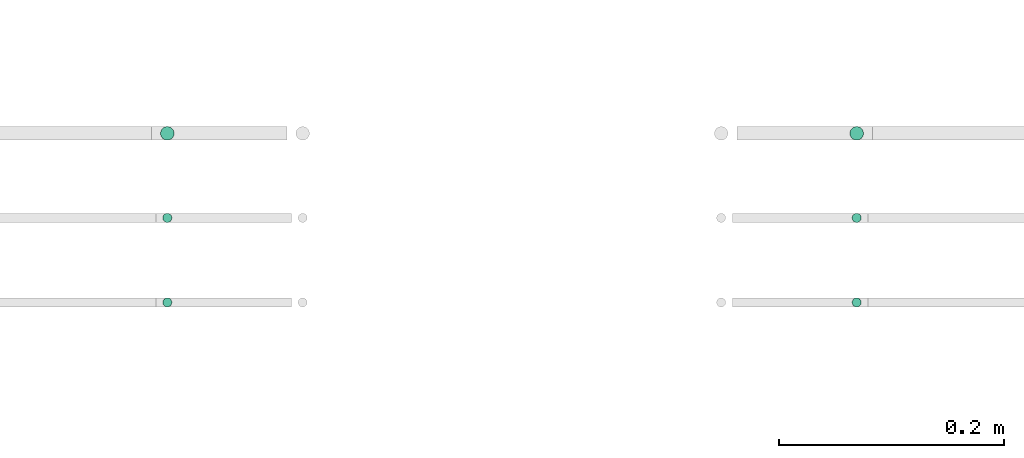
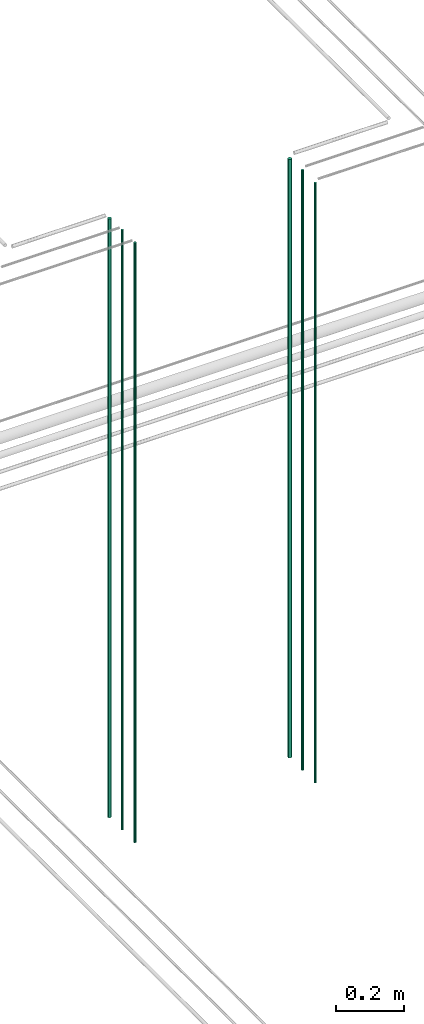
# One storey, part 8 of 331: 6 flow segments.
"""IFC2X3 building model written with IfcOpenShell, lengths in millimetres."""

from ifc_helpers import new_model, entity, si_unit, converted_unit, derived_unit, direction, frame, origin, origin_2d_with_axis, place, context, subcontext, project, spatial, circle, extrude, type_object, element, save


model = new_model("IFC2X3")

# Units and contexts
model_context = context("Model", 3, precision=0.01, world=origin(), true_north=direction((6.12303176911189e-17, 1.0)))
body_context = subcontext(model_context, "Body", "Model", "MODEL_VIEW")
ifc_project = project(units=[si_unit("LENGTHUNIT", "METRE", prefix="MILLI"), si_unit("AREAUNIT", "SQUARE_METRE"), si_unit("VOLUMEUNIT", "CUBIC_METRE"), converted_unit("PLANEANGLEUNIT", "DEGREE", entity("IfcRatioMeasure", 0.0174532925199433), si_unit("PLANEANGLEUNIT", "RADIAN"), dimensions=[0, 0, 0, 0, 0, 0, 0]), si_unit("MASSUNIT", "GRAM", prefix="KILO"), derived_unit("MASSDENSITYUNIT", [(si_unit("MASSUNIT", "GRAM", prefix="KILO"), 1), (si_unit("LENGTHUNIT", "METRE"), -3)]), derived_unit("MOMENTOFINERTIAUNIT", [(si_unit("LENGTHUNIT", "METRE"), 4)]), si_unit("TIMEUNIT", "SECOND"), si_unit("FREQUENCYUNIT", "HERTZ"), si_unit("THERMODYNAMICTEMPERATUREUNIT", "DEGREE_CELSIUS"), derived_unit("THERMALTRANSMITTANCEUNIT", [(si_unit("MASSUNIT", "GRAM", prefix="KILO"), 1), (si_unit("THERMODYNAMICTEMPERATUREUNIT", "KELVIN"), -1), (si_unit("TIMEUNIT", "SECOND"), -3)]), derived_unit("VOLUMETRICFLOWRATEUNIT", [(si_unit("LENGTHUNIT", "METRE"), 3), (si_unit("TIMEUNIT", "SECOND"), -1)]), derived_unit("MASSFLOWRATEUNIT", [(si_unit("MASSUNIT", "GRAM", prefix="KILO"), 1), (si_unit("TIMEUNIT", "SECOND"), -1)]), derived_unit("ROTATIONALFREQUENCYUNIT", [(si_unit("TIMEUNIT", "SECOND"), -1)]), si_unit("ELECTRICCURRENTUNIT", "AMPERE"), si_unit("ELECTRICVOLTAGEUNIT", "VOLT"), si_unit("POWERUNIT", "WATT"), si_unit("FORCEUNIT", "NEWTON", prefix="KILO"), si_unit("ILLUMINANCEUNIT", "LUX"), si_unit("LUMINOUSFLUXUNIT", "LUMEN"), si_unit("LUMINOUSINTENSITYUNIT", "CANDELA"), derived_unit("USERDEFINED", [(si_unit("MASSUNIT", "GRAM", prefix="KILO"), -1), (si_unit("LENGTHUNIT", "METRE"), -2), (si_unit("TIMEUNIT", "SECOND"), 3), (si_unit("LUMINOUSFLUXUNIT", "LUMEN"), 1)]), derived_unit("LINEARVELOCITYUNIT", [(si_unit("LENGTHUNIT", "METRE"), 1), (si_unit("TIMEUNIT", "SECOND"), -1)]), si_unit("PRESSUREUNIT", "PASCAL"), derived_unit("USERDEFINED", [(si_unit("LENGTHUNIT", "METRE"), -2), (si_unit("MASSUNIT", "GRAM", prefix="KILO"), 1), (si_unit("TIMEUNIT", "SECOND"), -2)]), derived_unit("LINEARFORCEUNIT", [(si_unit("MASSUNIT", "GRAM", prefix="KILO"), 1), (si_unit("LENGTHUNIT", "METRE"), 1), (si_unit("TIMEUNIT", "SECOND"), -2), (si_unit("LENGTHUNIT", "METRE"), -1)]), derived_unit("PLANARFORCEUNIT", [(si_unit("MASSUNIT", "GRAM", prefix="KILO"), 1), (si_unit("LENGTHUNIT", "METRE"), 1), (si_unit("TIMEUNIT", "SECOND"), -2), (si_unit("LENGTHUNIT", "METRE"), -2)])], contexts=[model_context])

# Site, building, storey
site_placement = place(None, frame((0.0, -0.00077364408347762, 0.0)))
site = spatial("IfcSite", under=ifc_project, at=site_placement, CompositionType="ELEMENT")
building_placement = place(site_placement, origin())
building = spatial("IfcBuilding", under=site, at=building_placement, CompositionType="ELEMENT")
storey_placement = place(building_placement, origin())
storey = spatial("IfcBuildingStorey", under=building, at=storey_placement, CompositionType="ELEMENT", Elevation=0.0)

# Flow segments
pipe_segment_type = type_object("IfcPipeSegmentType", PredefinedType="NOTDEFINED")
flow_segment_1_placement = place(storey_placement, frame((34657.8400837291, 1343.89349484378, 16890.0)))
element("IfcFlowSegment", 1, at=flow_segment_1_placement, inside=storey, type_object=pipe_segment_type, context=body_context, shape_type="SweptSolid", body=[
    extrude(circle(Radius=6.0, at=origin_2d_with_axis()), frame((7.59527223591454, 7.59527223591589, 0.0)), (0.0, 0.0, 1.0), 2146.0),
])
flow_segment_2_placement = place(storey_placement, frame((34659.8400837291, 1270.89349484379, 16890.0)))
element("IfcFlowSegment", 2, at=flow_segment_2_placement, inside=storey, type_object=pipe_segment_type, context=body_context, shape_type="SweptSolid", body=[
    extrude(circle(Radius=4.0, at=origin_2d_with_axis()), frame((5.59527223591499, 5.5952722359158, 0.0)), (0.0, 0.0, 1.0), 2150.00000000001),
])
flow_segment_3_placement = place(storey_placement, frame((34659.8400837291, 1195.89349484378, 16890.0)))
element("IfcFlowSegment", 3, at=flow_segment_3_placement, inside=storey, type_object=pipe_segment_type, context=body_context, shape_type="SweptSolid", body=[
    extrude(circle(Radius=4.0, at=origin_2d_with_axis()), frame((5.59527223591499, 5.59527223591607, 0.0)), (0.0, 0.0, 1.0), 2150.00000000001),
])
flow_segment_4_placement = place(storey_placement, frame((35269.3585217207, 1343.89349484378, 16890.0)))
element("IfcFlowSegment", 4, at=flow_segment_4_placement, inside=storey, type_object=pipe_segment_type, context=body_context, shape_type="SweptSolid", body=[
    extrude(circle(Radius=6.0, at=origin_2d_with_axis()), frame((7.59527223591454, 7.59527223591589, 0.0)), (0.0, 0.0, 1.0), 2146.0),
])
flow_segment_5_placement = place(storey_placement, frame((35271.3585217207, 1270.89349484379, 16890.0)))
element("IfcFlowSegment", 5, at=flow_segment_5_placement, inside=storey, type_object=pipe_segment_type, context=body_context, shape_type="SweptSolid", body=[
    extrude(circle(Radius=4.0, at=origin_2d_with_axis()), frame((5.59527223591499, 5.5952722359158, 0.0)), (0.0, 0.0, 1.0), 2150.00000000001),
])
flow_segment_6_placement = place(storey_placement, frame((35271.3585217207, 1195.89349484378, 16890.0)))
element("IfcFlowSegment", 6, at=flow_segment_6_placement, inside=storey, type_object=pipe_segment_type, context=body_context, shape_type="SweptSolid", body=[
    extrude(circle(Radius=4.0, at=origin_2d_with_axis()), frame((5.59527223591499, 5.59527223591607, 0.0)), (0.0, 0.0, 1.0), 2150.00000000001),
])

save(model, "model.ifc")
